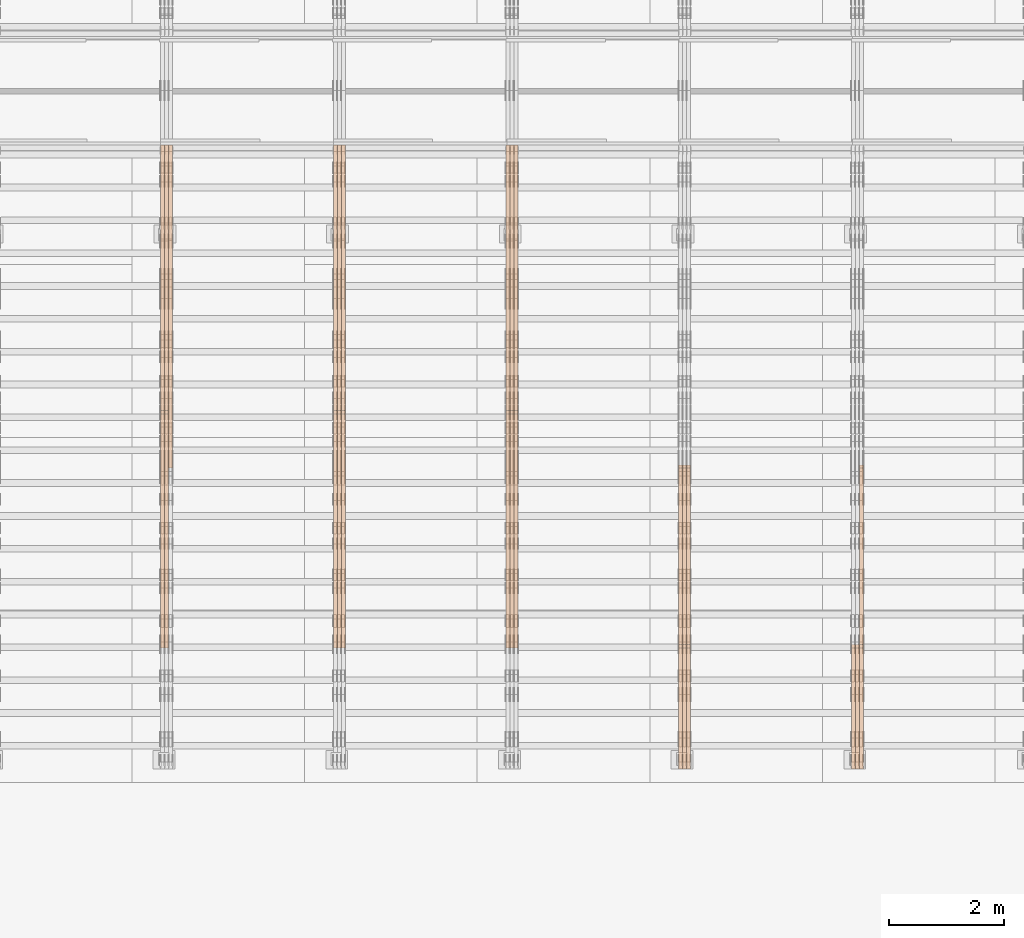
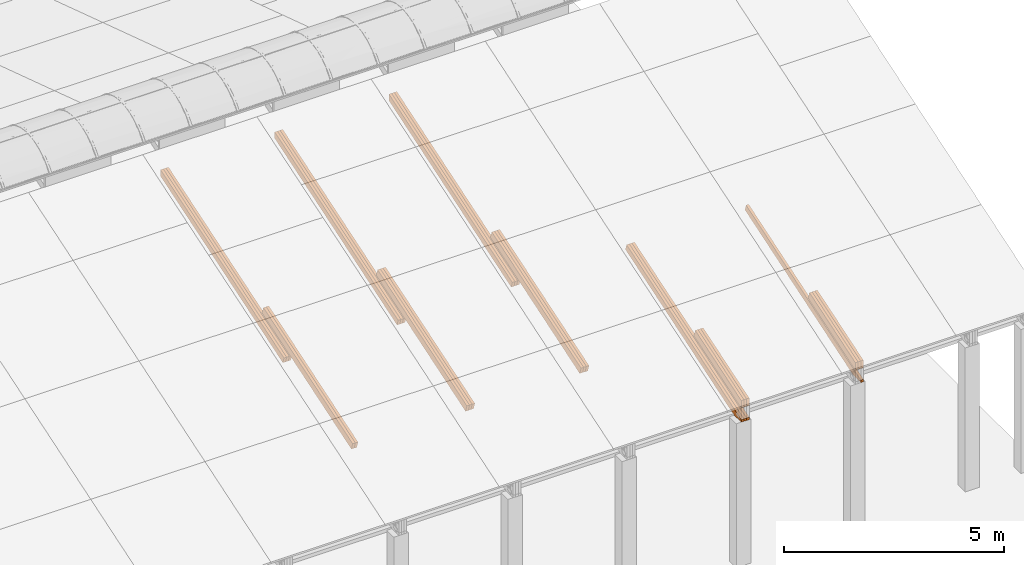
# One storey, part 25 of 385: 27 proxies.
"""IFC2X3 building model written with IfcOpenShell, lengths in millimetres."""

from ifc_helpers import new_model, entity, si_unit, converted_unit, derived_unit, direction, frame, origin, place, context, subcontext, project, spatial, polyline, outline, extrude, source, transform, mapped, material, type_object, type_shapes, element, save


model = new_model("IFC2X3")

# Units and contexts
model_context = context("Model", 3, precision=0.01, world=origin(), true_north=direction((6.12303176911189e-17, 1.0)))
body_context = subcontext(model_context, "Body", "Model", "MODEL_VIEW")
ifc_project = project(units=[si_unit("LENGTHUNIT", "METRE", prefix="MILLI"), si_unit("AREAUNIT", "SQUARE_METRE"), si_unit("VOLUMEUNIT", "CUBIC_METRE"), converted_unit("PLANEANGLEUNIT", "DEGREE", entity("IfcRatioMeasure", 0.0174532925199433), si_unit("PLANEANGLEUNIT", "RADIAN"), dimensions=[0, 0, 0, 0, 0, 0, 0]), si_unit("MASSUNIT", "GRAM", prefix="KILO"), derived_unit("MASSDENSITYUNIT", [(si_unit("MASSUNIT", "GRAM", prefix="KILO"), 1), (si_unit("LENGTHUNIT", "METRE"), -3)]), si_unit("TIMEUNIT", "SECOND"), si_unit("FREQUENCYUNIT", "HERTZ"), si_unit("THERMODYNAMICTEMPERATUREUNIT", "DEGREE_CELSIUS"), derived_unit("THERMALTRANSMITTANCEUNIT", [(si_unit("MASSUNIT", "GRAM", prefix="KILO"), 1), (si_unit("THERMODYNAMICTEMPERATUREUNIT", "KELVIN"), -1), (si_unit("TIMEUNIT", "SECOND"), -3)]), derived_unit("VOLUMETRICFLOWRATEUNIT", [(si_unit("LENGTHUNIT", "METRE"), 3), (si_unit("TIMEUNIT", "SECOND"), -1)]), si_unit("ELECTRICCURRENTUNIT", "AMPERE"), si_unit("ELECTRICVOLTAGEUNIT", "VOLT"), si_unit("POWERUNIT", "WATT"), si_unit("FORCEUNIT", "NEWTON", prefix="KILO"), si_unit("ILLUMINANCEUNIT", "LUX"), si_unit("LUMINOUSFLUXUNIT", "LUMEN"), si_unit("LUMINOUSINTENSITYUNIT", "CANDELA"), derived_unit("USERDEFINED", [(si_unit("MASSUNIT", "GRAM", prefix="KILO"), -1), (si_unit("LENGTHUNIT", "METRE"), -2), (si_unit("TIMEUNIT", "SECOND"), 3), (si_unit("LUMINOUSFLUXUNIT", "LUMEN"), 1)]), derived_unit("LINEARVELOCITYUNIT", [(si_unit("LENGTHUNIT", "METRE"), 1), (si_unit("TIMEUNIT", "SECOND"), -1)]), si_unit("PRESSUREUNIT", "PASCAL"), derived_unit("USERDEFINED", [(si_unit("LENGTHUNIT", "METRE"), -2), (si_unit("MASSUNIT", "GRAM", prefix="KILO"), 1), (si_unit("TIMEUNIT", "SECOND"), -2)])], contexts=[model_context])

# Site, building, storey
site_placement = place(None, origin())
site = spatial("IfcSite", under=ifc_project, at=site_placement, CompositionType="ELEMENT")
building_placement = place(site_placement, origin())
building = spatial("IfcBuilding", under=site, at=building_placement, CompositionType="ELEMENT")
storey_placement = place(building_placement, origin())
storey = spatial("IfcBuildingStorey", under=building, at=storey_placement, Name="Default", CompositionType="ELEMENT", Elevation=0.0)

# Proxies
ifc_material_1 = material(Name="IfcSurfaceStyle #524327")
building_element_proxy_type_1 = type_object("IfcBuildingElementProxyType", Name="T1-T3 524325", PredefinedType="NOTDEFINED", material=ifc_material_1)
shared_shape_1 = source(origin(), body_context, "Body", "SweptSolid", [
    extrude(outline(polyline([(-1085.54462735035, -97.5001496742589), (1117.22361141796, -97.5001496742589), (1117.22498157786, 97.5001496742589), (-1148.90396564547, 97.5001496742589), (-1085.54462735035, -97.5001496742589)])), frame((1117.22498157786, 97.5001496742589, 0.0), z_axis=(0.0, 0.0, 1.0), x_axis=(-1.0, 0.0, 0.0)), (0.0, 0.0, 1.0), 69.9999999999999),
])
type_shapes(building_element_proxy_type_1, [shared_shape_1])
proxy_1_placement = place(building_placement, frame((45385.0, 5095.216796875, 1095.23693847656), z_axis=(-1.0, 0.0, 0.0), x_axis=(0.0, -0.951056516295154, -0.309016994374948)))
element("IfcBuildingElementProxy", 1, at=proxy_1_placement, inside=storey, type_object=building_element_proxy_type_1, material=ifc_material_1, Name="T1-T3", context=body_context, shape_type="MappedRepresentation", body=[
    mapped(shared_shape_1, transform((0.0, 0.0, 0.0), scale=1.0)),
])
ifc_material_2 = material(Name="IfcSurfaceStyle #524270")
building_element_proxy_type_2 = type_object("IfcBuildingElementProxyType", Name="T1-T3 524268", PredefinedType="NOTDEFINED", material=ifc_material_2)
shared_shape_2 = source(origin(), body_context, "Body", "SweptSolid", [
    extrude(outline(polyline([(-1085.54462735035, -97.5001496742589), (1117.22361141796, -97.5001496742589), (1117.22498157786, 97.5001496742589), (-1148.90396564547, 97.5001496742589), (-1085.54462735035, -97.5001496742589)])), frame((1117.22498157786, 97.5001496742589, 0.0), z_axis=(0.0, 0.0, 1.0), x_axis=(-1.0, 0.0, 0.0)), (0.0, 0.0, 1.0), 69.9999999999999),
])
type_shapes(building_element_proxy_type_2, [shared_shape_2])
proxy_2_placement = place(building_placement, frame((45315.0, 5095.216796875, 1095.23693847656), z_axis=(-1.0, 0.0, 0.0), x_axis=(0.0, -0.951056516295154, -0.309016994374948)))
element("IfcBuildingElementProxy", 2, at=proxy_2_placement, inside=storey, type_object=building_element_proxy_type_2, material=ifc_material_2, Name="T1-T3", context=body_context, shape_type="MappedRepresentation", body=[
    mapped(shared_shape_2, transform((0.0, 0.0, 0.0), scale=1.0)),
])
ifc_material_3 = material(Name="IfcSurfaceStyle #524213")
building_element_proxy_type_3 = type_object("IfcBuildingElementProxyType", Name="T1-T3 524211", PredefinedType="NOTDEFINED", material=ifc_material_3)
shared_shape_3 = source(origin(), body_context, "Body", "SweptSolid", [
    extrude(outline(polyline([(-1085.54462735035, -97.5001496742589), (1117.22361141796, -97.5001496742589), (1117.22498157786, 97.5001496742589), (-1148.90396564547, 97.5001496742589), (-1085.54462735035, -97.5001496742589)])), frame((1117.22498157786, 97.5001496742589, 0.0), z_axis=(0.0, 0.0, 1.0), x_axis=(-1.0, 0.0, 0.0)), (0.0, 0.0, 1.0), 69.9999999999999),
])
type_shapes(building_element_proxy_type_3, [shared_shape_3])
proxy_3_placement = place(building_placement, frame((45245.0, 5095.216796875, 1095.23693847656), z_axis=(-1.0, 0.0, 0.0), x_axis=(0.0, -0.951056516295154, -0.309016994374948)))
element("IfcBuildingElementProxy", 3, at=proxy_3_placement, inside=storey, type_object=building_element_proxy_type_3, material=ifc_material_3, Name="T1-T3", context=body_context, shape_type="MappedRepresentation", body=[
    mapped(shared_shape_3, transform((0.0, 0.0, 0.0), scale=1.0)),
])
ifc_material_4 = material(Name="IfcSurfaceStyle #523643")
building_element_proxy_type_4 = type_object("IfcBuildingElementProxyType", Name="T1-B5 523641", PredefinedType="NOTDEFINED", material=ifc_material_4)
shared_shape_4 = source(origin(), body_context, "Body", "SweptSolid", [
    extrude(outline(polyline([(-3238.20553797979, -89.0131148793731), (1950.26357999126, -89.0131148793731), (2273.6227955316, 16.0525968934038), (2252.52438864378, 80.9868164326712), (-3238.20522618685, 80.9868164326712), (-3238.20553797979, -89.0131148793731)])), frame((2273.6227955316, 80.9869419088758, 0.0), z_axis=(0.0, 0.0, 1.0), x_axis=(-1.0, 0.0, 0.0)), (0.0, 0.0, 1.0), 69.9999999999997),
])
type_shapes(building_element_proxy_type_4, [shared_shape_4])
proxy_4_placement = place(building_placement, frame((45385.0, 2919.93418387162, 61.7562319586341), z_axis=(-1.0, 0.0, 0.0), x_axis=(0.0, 0.951056516295124, 0.309016994375039)))
element("IfcBuildingElementProxy", 4, at=proxy_4_placement, inside=storey, type_object=building_element_proxy_type_4, material=ifc_material_4, Name="T1-B5", context=body_context, shape_type="MappedRepresentation", body=[
    mapped(shared_shape_4, transform((0.0, 0.0, 0.0), scale=1.0)),
])
ifc_material_5 = material(Name="IfcSurfaceStyle #489895")
building_element_proxy_type_5 = type_object("IfcBuildingElementProxyType", Name="T1-T3 489893", PredefinedType="NOTDEFINED", material=ifc_material_5)
shared_shape_5 = source(origin(), body_context, "Body", "SweptSolid", [
    extrude(outline(polyline([(-1085.54462735035, -97.5001496742589), (1117.22361141796, -97.5001496742589), (1117.22498157786, 97.5001496742589), (-1148.90396564547, 97.5001496742589), (-1085.54462735035, -97.5001496742589)])), frame((1117.22498157786, 97.5001496742589, 0.0), z_axis=(0.0, 0.0, 1.0), x_axis=(-1.0, 0.0, 0.0)), (0.0, 0.0, 1.0), 69.9999999999999),
])
type_shapes(building_element_proxy_type_5, [shared_shape_5])
proxy_5_placement = place(building_placement, frame((42385.0, 5095.216796875, 1095.23693847656), z_axis=(-1.0, 0.0, 0.0), x_axis=(0.0, -0.951056516295154, -0.309016994374948)))
element("IfcBuildingElementProxy", 5, at=proxy_5_placement, inside=storey, type_object=building_element_proxy_type_5, material=ifc_material_5, Name="T1-T3", context=body_context, shape_type="MappedRepresentation", body=[
    mapped(shared_shape_5, transform((0.0, 0.0, 0.0), scale=1.0)),
])
ifc_material_6 = material(Name="IfcSurfaceStyle #489838")
building_element_proxy_type_6 = type_object("IfcBuildingElementProxyType", Name="T1-T3 489836", PredefinedType="NOTDEFINED", material=ifc_material_6)
shared_shape_6 = source(origin(), body_context, "Body", "SweptSolid", [
    extrude(outline(polyline([(-1085.54462735035, -97.5001496742589), (1117.22361141796, -97.5001496742589), (1117.22498157786, 97.5001496742589), (-1148.90396564547, 97.5001496742589), (-1085.54462735035, -97.5001496742589)])), frame((1117.22498157786, 97.5001496742589, 0.0), z_axis=(0.0, 0.0, 1.0), x_axis=(-1.0, 0.0, 0.0)), (0.0, 0.0, 1.0), 69.9999999999999),
])
type_shapes(building_element_proxy_type_6, [shared_shape_6])
proxy_6_placement = place(building_placement, frame((42315.0, 5095.216796875, 1095.23693847656), z_axis=(-1.0, 0.0, 0.0), x_axis=(0.0, -0.951056516295154, -0.309016994374948)))
element("IfcBuildingElementProxy", 6, at=proxy_6_placement, inside=storey, type_object=building_element_proxy_type_6, material=ifc_material_6, Name="T1-T3", context=body_context, shape_type="MappedRepresentation", body=[
    mapped(shared_shape_6, transform((0.0, 0.0, 0.0), scale=1.0)),
])
ifc_material_7 = material(Name="IfcSurfaceStyle #489781")
building_element_proxy_type_7 = type_object("IfcBuildingElementProxyType", Name="T1-T3 489779", PredefinedType="NOTDEFINED", material=ifc_material_7)
shared_shape_7 = source(origin(), body_context, "Body", "SweptSolid", [
    extrude(outline(polyline([(-1085.54462735035, -97.5001496742589), (1117.22361141796, -97.5001496742589), (1117.22498157786, 97.5001496742589), (-1148.90396564547, 97.5001496742589), (-1085.54462735035, -97.5001496742589)])), frame((1117.22498157786, 97.5001496742589, 0.0), z_axis=(0.0, 0.0, 1.0), x_axis=(-1.0, 0.0, 0.0)), (0.0, 0.0, 1.0), 69.9999999999999),
])
type_shapes(building_element_proxy_type_7, [shared_shape_7])
proxy_7_placement = place(building_placement, frame((42245.0, 5095.216796875, 1095.23693847656), z_axis=(-1.0, 0.0, 0.0), x_axis=(0.0, -0.951056516295154, -0.309016994374948)))
element("IfcBuildingElementProxy", 7, at=proxy_7_placement, inside=storey, type_object=building_element_proxy_type_7, material=ifc_material_7, Name="T1-T3", context=body_context, shape_type="MappedRepresentation", body=[
    mapped(shared_shape_7, transform((0.0, 0.0, 0.0), scale=1.0)),
])
ifc_material_8 = material(Name="IfcSurfaceStyle #489211")
building_element_proxy_type_8 = type_object("IfcBuildingElementProxyType", Name="T1-B5 489209", PredefinedType="NOTDEFINED", material=ifc_material_8)
shared_shape_8 = source(origin(), body_context, "Body", "SweptSolid", [
    extrude(outline(polyline([(-3238.20553797979, -89.0131148793731), (1950.26357999126, -89.0131148793731), (2273.6227955316, 16.0525968934038), (2252.52438864378, 80.9868164326712), (-3238.20522618685, 80.9868164326712), (-3238.20553797979, -89.0131148793731)])), frame((2273.6227955316, 80.9869419088758, 0.0), z_axis=(0.0, 0.0, 1.0), x_axis=(-1.0, 0.0, 0.0)), (0.0, 0.0, 1.0), 69.9999999999997),
])
type_shapes(building_element_proxy_type_8, [shared_shape_8])
proxy_8_placement = place(building_placement, frame((42385.0, 2919.93418387161, 61.7562319586341), z_axis=(-1.0, 0.0, 0.0), x_axis=(0.0, 0.951056516295124, 0.309016994375039)))
element("IfcBuildingElementProxy", 8, at=proxy_8_placement, inside=storey, type_object=building_element_proxy_type_8, material=ifc_material_8, Name="T1-B5", context=body_context, shape_type="MappedRepresentation", body=[
    mapped(shared_shape_8, transform((0.0, 0.0, 0.0), scale=1.0)),
])
ifc_material_9 = material(Name="IfcSurfaceStyle #489145")
building_element_proxy_type_9 = type_object("IfcBuildingElementProxyType", Name="T1-B5 489143", PredefinedType="NOTDEFINED", material=ifc_material_9)
shared_shape_9 = source(origin(), body_context, "Body", "SweptSolid", [
    extrude(outline(polyline([(-3238.20553797979, -89.0131148793731), (1950.26357999126, -89.0131148793731), (2273.6227955316, 16.0525968934038), (2252.52438864378, 80.9868164326712), (-3238.20522618685, 80.9868164326712), (-3238.20553797979, -89.0131148793731)])), frame((2273.6227955316, 80.9869419088758, 0.0), z_axis=(0.0, 0.0, 1.0), x_axis=(-1.0, 0.0, 0.0)), (0.0, 0.0, 1.0), 69.9999999999997),
])
type_shapes(building_element_proxy_type_9, [shared_shape_9])
proxy_9_placement = place(building_placement, frame((42315.0, 2919.93418387161, 61.7562319586341), z_axis=(-1.0, 0.0, 0.0), x_axis=(0.0, 0.951056516295124, 0.309016994375039)))
element("IfcBuildingElementProxy", 9, at=proxy_9_placement, inside=storey, type_object=building_element_proxy_type_9, material=ifc_material_9, Name="T1-B5", context=body_context, shape_type="MappedRepresentation", body=[
    mapped(shared_shape_9, transform((0.0, 0.0, 0.0), scale=1.0)),
])
ifc_material_10 = material(Name="IfcSurfaceStyle #489079")
building_element_proxy_type_10 = type_object("IfcBuildingElementProxyType", Name="T1-B5 489077", PredefinedType="NOTDEFINED", material=ifc_material_10)
shared_shape_10 = source(origin(), body_context, "Body", "SweptSolid", [
    extrude(outline(polyline([(-3238.20553797979, -89.0131148793731), (1950.26357999126, -89.0131148793731), (2273.6227955316, 16.0525968934038), (2252.52438864378, 80.9868164326712), (-3238.20522618685, 80.9868164326712), (-3238.20553797979, -89.0131148793731)])), frame((2273.6227955316, 80.9869419088758, 0.0), z_axis=(0.0, 0.0, 1.0), x_axis=(-1.0, 0.0, 0.0)), (0.0, 0.0, 1.0), 69.9999999999997),
])
type_shapes(building_element_proxy_type_10, [shared_shape_10])
proxy_10_placement = place(building_placement, frame((42245.0, 2919.93418387161, 61.7562319586341), z_axis=(-1.0, 0.0, 0.0), x_axis=(0.0, 0.951056516295124, 0.309016994375039)))
element("IfcBuildingElementProxy", 10, at=proxy_10_placement, inside=storey, type_object=building_element_proxy_type_10, material=ifc_material_10, Name="T1-B5", context=body_context, shape_type="MappedRepresentation", body=[
    mapped(shared_shape_10, transform((0.0, 0.0, 0.0), scale=1.0)),
])
ifc_material_11 = material(Name="IfcSurfaceStyle #455292")
building_element_proxy_type_11 = type_object("IfcBuildingElementProxyType", Name="T1-T2 455290", PredefinedType="NOTDEFINED", material=ifc_material_11)
shared_shape_11 = source(origin(), body_context, "Body", "SweptSolid", [
    extrude(outline(polyline([(-2137.04475371072, -97.5001541485635), (2137.04431231695, -97.5001541485635), (2137.0438249446, 97.5001541485636), (-2137.04338355082, 97.5001541485635), (-2137.04475371072, -97.5001541485635)])), frame((2137.04431231695, 97.5003268035489, 0.0), z_axis=(0.0, 0.0, 1.0), x_axis=(-1.0, 0.0, 0.0)), (0.0, 0.0, 1.0), 69.9999999999997),
])
type_shapes(building_element_proxy_type_11, [shared_shape_11])
proxy_11_placement = place(building_placement, frame((39385.0, 9160.11575124698, 2416.00267194857), z_axis=(-1.0, 0.0, 0.0), x_axis=(0.0, -0.951056516295154, -0.309016994374948)))
element("IfcBuildingElementProxy", 11, at=proxy_11_placement, inside=storey, type_object=building_element_proxy_type_11, material=ifc_material_11, Name="T1-T2", context=body_context, shape_type="MappedRepresentation", body=[
    mapped(shared_shape_11, transform((0.0, 0.0, 0.0), scale=1.0)),
])
ifc_material_12 = material(Name="IfcSurfaceStyle #455235")
building_element_proxy_type_12 = type_object("IfcBuildingElementProxyType", Name="T1-T2 455233", PredefinedType="NOTDEFINED", material=ifc_material_12)
shared_shape_12 = source(origin(), body_context, "Body", "SweptSolid", [
    extrude(outline(polyline([(-2137.04475371072, -97.5001541485635), (2137.04431231695, -97.5001541485635), (2137.0438249446, 97.5001541485636), (-2137.04338355082, 97.5001541485635), (-2137.04475371072, -97.5001541485635)])), frame((2137.04431231695, 97.5003268035489, 0.0), z_axis=(0.0, 0.0, 1.0), x_axis=(-1.0, 0.0, 0.0)), (0.0, 0.0, 1.0), 69.9999999999997),
])
type_shapes(building_element_proxy_type_12, [shared_shape_12])
proxy_12_placement = place(building_placement, frame((39315.0, 9160.11575124698, 2416.00267194857), z_axis=(-1.0, 0.0, 0.0), x_axis=(0.0, -0.951056516295154, -0.309016994374948)))
element("IfcBuildingElementProxy", 12, at=proxy_12_placement, inside=storey, type_object=building_element_proxy_type_12, material=ifc_material_12, Name="T1-T2", context=body_context, shape_type="MappedRepresentation", body=[
    mapped(shared_shape_12, transform((0.0, 0.0, 0.0), scale=1.0)),
])
ifc_material_13 = material(Name="IfcSurfaceStyle #455178")
building_element_proxy_type_13 = type_object("IfcBuildingElementProxyType", Name="T1-T2 455176", PredefinedType="NOTDEFINED", material=ifc_material_13)
shared_shape_13 = source(origin(), body_context, "Body", "SweptSolid", [
    extrude(outline(polyline([(-2137.04475371072, -97.5001541485635), (2137.04431231695, -97.5001541485635), (2137.0438249446, 97.5001541485636), (-2137.04338355082, 97.5001541485635), (-2137.04475371072, -97.5001541485635)])), frame((2137.04431231695, 97.5003268035489, 0.0), z_axis=(0.0, 0.0, 1.0), x_axis=(-1.0, 0.0, 0.0)), (0.0, 0.0, 1.0), 69.9999999999997),
])
type_shapes(building_element_proxy_type_13, [shared_shape_13])
proxy_13_placement = place(building_placement, frame((39245.0, 9160.11575124698, 2416.00267194857), z_axis=(-1.0, 0.0, 0.0), x_axis=(0.0, -0.951056516295154, -0.309016994374948)))
element("IfcBuildingElementProxy", 13, at=proxy_13_placement, inside=storey, type_object=building_element_proxy_type_13, material=ifc_material_13, Name="T1-T2", context=body_context, shape_type="MappedRepresentation", body=[
    mapped(shared_shape_13, transform((0.0, 0.0, 0.0), scale=1.0)),
])
ifc_material_14 = material(Name="IfcSurfaceStyle #454950")
building_element_proxy_type_14 = type_object("IfcBuildingElementProxyType", Name="T1-B4 454948", PredefinedType="NOTDEFINED", material=ifc_material_14)
shared_shape_14 = source(origin(), body_context, "Body", "SweptSolid", [
    extrude(outline(polyline([(-2912.13310129284, -85.0000958683222), (2939.75111293783, -85.0000958683222), (2939.75142473078, 85.0000958683222), (-2967.36943637577, 85.0000958683222), (-2912.13310129284, -85.0000958683222)])), frame((2939.75142473078, 85.0000958683222, 0.0), z_axis=(0.0, 0.0, 1.0), x_axis=(-1.0, 0.0, 0.0)), (0.0, 0.0, 1.0), 69.9999999999996),
])
type_shapes(building_element_proxy_type_14, [shared_shape_14])
proxy_14_placement = place(building_placement, frame((39385.0, 8161.994140625, 1765.00476074219), z_axis=(-1.0, 0.0, 0.0), x_axis=(0.0, 0.951056516295124, 0.309016994375039)))
element("IfcBuildingElementProxy", 14, at=proxy_14_placement, inside=storey, type_object=building_element_proxy_type_14, material=ifc_material_14, Name="T1-B4", context=body_context, shape_type="MappedRepresentation", body=[
    mapped(shared_shape_14, transform((0.0, 0.0, 0.0), scale=1.0)),
])
ifc_material_15 = material(Name="IfcSurfaceStyle #454893")
building_element_proxy_type_15 = type_object("IfcBuildingElementProxyType", Name="T1-B4 454891", PredefinedType="NOTDEFINED", material=ifc_material_15)
shared_shape_15 = source(origin(), body_context, "Body", "SweptSolid", [
    extrude(outline(polyline([(-2912.13310129284, -85.0000958683222), (2939.75111293783, -85.0000958683222), (2939.75142473078, 85.0000958683222), (-2967.36943637577, 85.0000958683222), (-2912.13310129284, -85.0000958683222)])), frame((2939.75142473078, 85.0000958683222, 0.0), z_axis=(0.0, 0.0, 1.0), x_axis=(-1.0, 0.0, 0.0)), (0.0, 0.0, 1.0), 69.9999999999996),
])
type_shapes(building_element_proxy_type_15, [shared_shape_15])
proxy_15_placement = place(building_placement, frame((39315.0, 8161.994140625, 1765.00476074219), z_axis=(-1.0, 0.0, 0.0), x_axis=(0.0, 0.951056516295124, 0.309016994375039)))
element("IfcBuildingElementProxy", 15, at=proxy_15_placement, inside=storey, type_object=building_element_proxy_type_15, material=ifc_material_15, Name="T1-B4", context=body_context, shape_type="MappedRepresentation", body=[
    mapped(shared_shape_15, transform((0.0, 0.0, 0.0), scale=1.0)),
])
ifc_material_16 = material(Name="IfcSurfaceStyle #454836")
building_element_proxy_type_16 = type_object("IfcBuildingElementProxyType", Name="T1-B4 454834", PredefinedType="NOTDEFINED", material=ifc_material_16)
shared_shape_16 = source(origin(), body_context, "Body", "SweptSolid", [
    extrude(outline(polyline([(-2912.13310129284, -85.0000958683222), (2939.75111293783, -85.0000958683222), (2939.75142473078, 85.0000958683222), (-2967.36943637577, 85.0000958683222), (-2912.13310129284, -85.0000958683222)])), frame((2939.75142473078, 85.0000958683222, 0.0), z_axis=(0.0, 0.0, 1.0), x_axis=(-1.0, 0.0, 0.0)), (0.0, 0.0, 1.0), 69.9999999999996),
])
type_shapes(building_element_proxy_type_16, [shared_shape_16])
proxy_16_placement = place(building_placement, frame((39245.0, 8161.994140625, 1765.00476074219), z_axis=(-1.0, 0.0, 0.0), x_axis=(0.0, 0.951056516295124, 0.309016994375039)))
element("IfcBuildingElementProxy", 16, at=proxy_16_placement, inside=storey, type_object=building_element_proxy_type_16, material=ifc_material_16, Name="T1-B4", context=body_context, shape_type="MappedRepresentation", body=[
    mapped(shared_shape_16, transform((0.0, 0.0, 0.0), scale=1.0)),
])
ifc_material_17 = material(Name="IfcSurfaceStyle #420860")
building_element_proxy_type_17 = type_object("IfcBuildingElementProxyType", Name="T1-T2 420858", PredefinedType="NOTDEFINED", material=ifc_material_17)
shared_shape_17 = source(origin(), body_context, "Body", "SweptSolid", [
    extrude(outline(polyline([(-2137.04475371072, -97.5001541485635), (2137.04431231695, -97.5001541485635), (2137.0438249446, 97.5001541485636), (-2137.04338355082, 97.5001541485635), (-2137.04475371072, -97.5001541485635)])), frame((2137.04431231695, 97.5003268035489, 0.0), z_axis=(0.0, 0.0, 1.0), x_axis=(-1.0, 0.0, 0.0)), (0.0, 0.0, 1.0), 69.9999999999997),
])
type_shapes(building_element_proxy_type_17, [shared_shape_17])
proxy_17_placement = place(building_placement, frame((36385.0, 9160.11575124697, 2416.00267194857), z_axis=(-1.0, 0.0, 0.0), x_axis=(0.0, -0.951056516295154, -0.309016994374948)))
element("IfcBuildingElementProxy", 17, at=proxy_17_placement, inside=storey, type_object=building_element_proxy_type_17, material=ifc_material_17, Name="T1-T2", context=body_context, shape_type="MappedRepresentation", body=[
    mapped(shared_shape_17, transform((0.0, 0.0, 0.0), scale=1.0)),
])
ifc_material_18 = material(Name="IfcSurfaceStyle #420803")
building_element_proxy_type_18 = type_object("IfcBuildingElementProxyType", Name="T1-T2 420801", PredefinedType="NOTDEFINED", material=ifc_material_18)
shared_shape_18 = source(origin(), body_context, "Body", "SweptSolid", [
    extrude(outline(polyline([(-2137.04475371072, -97.5001541485635), (2137.04431231695, -97.5001541485635), (2137.0438249446, 97.5001541485636), (-2137.04338355082, 97.5001541485635), (-2137.04475371072, -97.5001541485635)])), frame((2137.04431231695, 97.5003268035489, 0.0), z_axis=(0.0, 0.0, 1.0), x_axis=(-1.0, 0.0, 0.0)), (0.0, 0.0, 1.0), 69.9999999999997),
])
type_shapes(building_element_proxy_type_18, [shared_shape_18])
proxy_18_placement = place(building_placement, frame((36315.0, 9160.11575124697, 2416.00267194857), z_axis=(-1.0, 0.0, 0.0), x_axis=(0.0, -0.951056516295154, -0.309016994374948)))
element("IfcBuildingElementProxy", 18, at=proxy_18_placement, inside=storey, type_object=building_element_proxy_type_18, material=ifc_material_18, Name="T1-T2", context=body_context, shape_type="MappedRepresentation", body=[
    mapped(shared_shape_18, transform((0.0, 0.0, 0.0), scale=1.0)),
])
ifc_material_19 = material(Name="IfcSurfaceStyle #420746")
building_element_proxy_type_19 = type_object("IfcBuildingElementProxyType", Name="T1-T2 420744", PredefinedType="NOTDEFINED", material=ifc_material_19)
shared_shape_19 = source(origin(), body_context, "Body", "SweptSolid", [
    extrude(outline(polyline([(-2137.04475371072, -97.5001541485635), (2137.04431231695, -97.5001541485635), (2137.0438249446, 97.5001541485636), (-2137.04338355082, 97.5001541485635), (-2137.04475371072, -97.5001541485635)])), frame((2137.04431231695, 97.5003268035489, 0.0), z_axis=(0.0, 0.0, 1.0), x_axis=(-1.0, 0.0, 0.0)), (0.0, 0.0, 1.0), 69.9999999999997),
])
type_shapes(building_element_proxy_type_19, [shared_shape_19])
proxy_19_placement = place(building_placement, frame((36245.0, 9160.11575124697, 2416.00267194857), z_axis=(-1.0, 0.0, 0.0), x_axis=(0.0, -0.951056516295154, -0.309016994374948)))
element("IfcBuildingElementProxy", 19, at=proxy_19_placement, inside=storey, type_object=building_element_proxy_type_19, material=ifc_material_19, Name="T1-T2", context=body_context, shape_type="MappedRepresentation", body=[
    mapped(shared_shape_19, transform((0.0, 0.0, 0.0), scale=1.0)),
])
ifc_material_20 = material(Name="IfcSurfaceStyle #420518")
building_element_proxy_type_20 = type_object("IfcBuildingElementProxyType", Name="T1-B4 420516", PredefinedType="NOTDEFINED", material=ifc_material_20)
shared_shape_20 = source(origin(), body_context, "Body", "SweptSolid", [
    extrude(outline(polyline([(-2912.13310129284, -85.0000958683222), (2939.75111293783, -85.0000958683222), (2939.75142473078, 85.0000958683222), (-2967.36943637577, 85.0000958683222), (-2912.13310129284, -85.0000958683222)])), frame((2939.75142473078, 85.0000958683222, 0.0), z_axis=(0.0, 0.0, 1.0), x_axis=(-1.0, 0.0, 0.0)), (0.0, 0.0, 1.0), 69.9999999999996),
])
type_shapes(building_element_proxy_type_20, [shared_shape_20])
proxy_20_placement = place(building_placement, frame((36385.0, 8161.994140625, 1765.00476074219), z_axis=(-1.0, 0.0, 0.0), x_axis=(0.0, 0.951056516295124, 0.309016994375039)))
element("IfcBuildingElementProxy", 20, at=proxy_20_placement, inside=storey, type_object=building_element_proxy_type_20, material=ifc_material_20, Name="T1-B4", context=body_context, shape_type="MappedRepresentation", body=[
    mapped(shared_shape_20, transform((0.0, 0.0, 0.0), scale=1.0)),
])
ifc_material_21 = material(Name="IfcSurfaceStyle #420461")
building_element_proxy_type_21 = type_object("IfcBuildingElementProxyType", Name="T1-B4 420459", PredefinedType="NOTDEFINED", material=ifc_material_21)
shared_shape_21 = source(origin(), body_context, "Body", "SweptSolid", [
    extrude(outline(polyline([(-2912.13310129284, -85.0000958683222), (2939.75111293783, -85.0000958683222), (2939.75142473078, 85.0000958683222), (-2967.36943637577, 85.0000958683222), (-2912.13310129284, -85.0000958683222)])), frame((2939.75142473078, 85.0000958683222, 0.0), z_axis=(0.0, 0.0, 1.0), x_axis=(-1.0, 0.0, 0.0)), (0.0, 0.0, 1.0), 69.9999999999996),
])
type_shapes(building_element_proxy_type_21, [shared_shape_21])
proxy_21_placement = place(building_placement, frame((36315.0, 8161.994140625, 1765.00476074219), z_axis=(-1.0, 0.0, 0.0), x_axis=(0.0, 0.951056516295124, 0.309016994375039)))
element("IfcBuildingElementProxy", 21, at=proxy_21_placement, inside=storey, type_object=building_element_proxy_type_21, material=ifc_material_21, Name="T1-B4", context=body_context, shape_type="MappedRepresentation", body=[
    mapped(shared_shape_21, transform((0.0, 0.0, 0.0), scale=1.0)),
])
ifc_material_22 = material(Name="IfcSurfaceStyle #420404")
building_element_proxy_type_22 = type_object("IfcBuildingElementProxyType", Name="T1-B4 420402", PredefinedType="NOTDEFINED", material=ifc_material_22)
shared_shape_22 = source(origin(), body_context, "Body", "SweptSolid", [
    extrude(outline(polyline([(-2912.13310129284, -85.0000958683222), (2939.75111293783, -85.0000958683222), (2939.75142473078, 85.0000958683222), (-2967.36943637577, 85.0000958683222), (-2912.13310129284, -85.0000958683222)])), frame((2939.75142473078, 85.0000958683222, 0.0), z_axis=(0.0, 0.0, 1.0), x_axis=(-1.0, 0.0, 0.0)), (0.0, 0.0, 1.0), 69.9999999999996),
])
type_shapes(building_element_proxy_type_22, [shared_shape_22])
proxy_22_placement = place(building_placement, frame((36245.0, 8161.994140625, 1765.00476074219), z_axis=(-1.0, 0.0, 0.0), x_axis=(0.0, 0.951056516295124, 0.309016994375039)))
element("IfcBuildingElementProxy", 22, at=proxy_22_placement, inside=storey, type_object=building_element_proxy_type_22, material=ifc_material_22, Name="T1-B4", context=body_context, shape_type="MappedRepresentation", body=[
    mapped(shared_shape_22, transform((0.0, 0.0, 0.0), scale=1.0)),
])
ifc_material_23 = material(Name="IfcSurfaceStyle #386371")
building_element_proxy_type_23 = type_object("IfcBuildingElementProxyType", Name="T1-T2 386369", PredefinedType="NOTDEFINED", material=ifc_material_23)
shared_shape_23 = source(origin(), body_context, "Body", "SweptSolid", [
    extrude(outline(polyline([(-2137.04475371072, -97.5001541485635), (2137.04431231695, -97.5001541485635), (2137.0438249446, 97.5001541485636), (-2137.04338355082, 97.5001541485635), (-2137.04475371072, -97.5001541485635)])), frame((2137.04431231695, 97.5003268035489, 0.0), z_axis=(0.0, 0.0, 1.0), x_axis=(-1.0, 0.0, 0.0)), (0.0, 0.0, 1.0), 69.9999999999997),
])
type_shapes(building_element_proxy_type_23, [shared_shape_23])
proxy_23_placement = place(building_placement, frame((33315.0, 9160.11575124697, 2416.00267194857), z_axis=(-1.0, 0.0, 0.0), x_axis=(0.0, -0.951056516295154, -0.309016994374948)))
element("IfcBuildingElementProxy", 23, at=proxy_23_placement, inside=storey, type_object=building_element_proxy_type_23, material=ifc_material_23, Name="T1-T2", context=body_context, shape_type="MappedRepresentation", body=[
    mapped(shared_shape_23, transform((0.0, 0.0, 0.0), scale=1.0)),
])
ifc_material_24 = material(Name="IfcSurfaceStyle #386314")
building_element_proxy_type_24 = type_object("IfcBuildingElementProxyType", Name="T1-T2 386312", PredefinedType="NOTDEFINED", material=ifc_material_24)
shared_shape_24 = source(origin(), body_context, "Body", "SweptSolid", [
    extrude(outline(polyline([(-2137.04475371072, -97.5001541485635), (2137.04431231695, -97.5001541485635), (2137.0438249446, 97.5001541485636), (-2137.04338355082, 97.5001541485635), (-2137.04475371072, -97.5001541485635)])), frame((2137.04431231695, 97.5003268035489, 0.0), z_axis=(0.0, 0.0, 1.0), x_axis=(-1.0, 0.0, 0.0)), (0.0, 0.0, 1.0), 69.9999999999997),
])
type_shapes(building_element_proxy_type_24, [shared_shape_24])
proxy_24_placement = place(building_placement, frame((33245.0, 9160.11575124697, 2416.00267194857), z_axis=(-1.0, 0.0, 0.0), x_axis=(0.0, -0.951056516295154, -0.309016994374948)))
element("IfcBuildingElementProxy", 24, at=proxy_24_placement, inside=storey, type_object=building_element_proxy_type_24, material=ifc_material_24, Name="T1-T2", context=body_context, shape_type="MappedRepresentation", body=[
    mapped(shared_shape_24, transform((0.0, 0.0, 0.0), scale=1.0)),
])
ifc_material_25 = material(Name="IfcSurfaceStyle #386086")
building_element_proxy_type_25 = type_object("IfcBuildingElementProxyType", Name="T1-B4 386084", PredefinedType="NOTDEFINED", material=ifc_material_25)
shared_shape_25 = source(origin(), body_context, "Body", "SweptSolid", [
    extrude(outline(polyline([(-2912.13310129284, -85.0000958683222), (2939.75111293783, -85.0000958683222), (2939.75142473078, 85.0000958683222), (-2967.36943637577, 85.0000958683222), (-2912.13310129284, -85.0000958683222)])), frame((2939.75142473078, 85.0000958683222, 0.0), z_axis=(0.0, 0.0, 1.0), x_axis=(-1.0, 0.0, 0.0)), (0.0, 0.0, 1.0), 69.9999999999996),
])
type_shapes(building_element_proxy_type_25, [shared_shape_25])
proxy_25_placement = place(building_placement, frame((33385.0, 8161.994140625, 1765.00476074219), z_axis=(-1.0, 0.0, 0.0), x_axis=(0.0, 0.951056516295124, 0.309016994375039)))
element("IfcBuildingElementProxy", 25, at=proxy_25_placement, inside=storey, type_object=building_element_proxy_type_25, material=ifc_material_25, Name="T1-B4", context=body_context, shape_type="MappedRepresentation", body=[
    mapped(shared_shape_25, transform((0.0, 0.0, 0.0), scale=1.0)),
])
ifc_material_26 = material(Name="IfcSurfaceStyle #386029")
building_element_proxy_type_26 = type_object("IfcBuildingElementProxyType", Name="T1-B4 386027", PredefinedType="NOTDEFINED", material=ifc_material_26)
shared_shape_26 = source(origin(), body_context, "Body", "SweptSolid", [
    extrude(outline(polyline([(-2912.13310129284, -85.0000958683222), (2939.75111293783, -85.0000958683222), (2939.75142473078, 85.0000958683222), (-2967.36943637577, 85.0000958683222), (-2912.13310129284, -85.0000958683222)])), frame((2939.75142473078, 85.0000958683222, 0.0), z_axis=(0.0, 0.0, 1.0), x_axis=(-1.0, 0.0, 0.0)), (0.0, 0.0, 1.0), 69.9999999999996),
])
type_shapes(building_element_proxy_type_26, [shared_shape_26])
proxy_26_placement = place(building_placement, frame((33315.0, 8161.994140625, 1765.00476074219), z_axis=(-1.0, 0.0, 0.0), x_axis=(0.0, 0.951056516295124, 0.309016994375039)))
element("IfcBuildingElementProxy", 26, at=proxy_26_placement, inside=storey, type_object=building_element_proxy_type_26, material=ifc_material_26, Name="T1-B4", context=body_context, shape_type="MappedRepresentation", body=[
    mapped(shared_shape_26, transform((0.0, 0.0, 0.0), scale=1.0)),
])
ifc_material_27 = material(Name="IfcSurfaceStyle #385972")
building_element_proxy_type_27 = type_object("IfcBuildingElementProxyType", Name="T1-B4 385970", PredefinedType="NOTDEFINED", material=ifc_material_27)
shared_shape_27 = source(origin(), body_context, "Body", "SweptSolid", [
    extrude(outline(polyline([(-2912.13310129284, -85.0000958683222), (2939.75111293783, -85.0000958683222), (2939.75142473078, 85.0000958683222), (-2967.36943637577, 85.0000958683222), (-2912.13310129284, -85.0000958683222)])), frame((2939.75142473078, 85.0000958683222, 0.0), z_axis=(0.0, 0.0, 1.0), x_axis=(-1.0, 0.0, 0.0)), (0.0, 0.0, 1.0), 69.9999999999996),
])
type_shapes(building_element_proxy_type_27, [shared_shape_27])
proxy_27_placement = place(building_placement, frame((33245.0, 8161.994140625, 1765.00476074219), z_axis=(-1.0, 0.0, 0.0), x_axis=(0.0, 0.951056516295124, 0.309016994375039)))
element("IfcBuildingElementProxy", 27, at=proxy_27_placement, inside=storey, type_object=building_element_proxy_type_27, material=ifc_material_27, Name="T1-B4", context=body_context, shape_type="MappedRepresentation", body=[
    mapped(shared_shape_27, transform((0.0, 0.0, 0.0), scale=1.0)),
])

save(model, "model.ifc")
